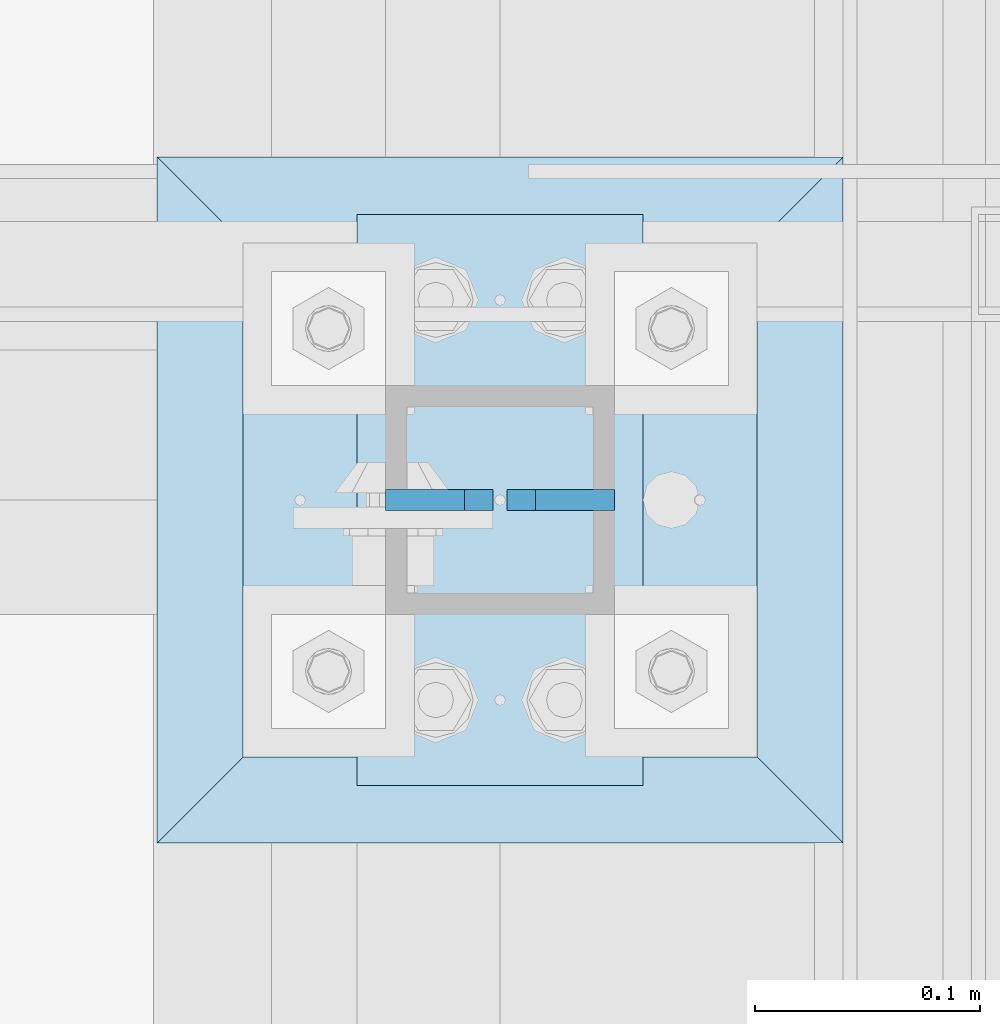
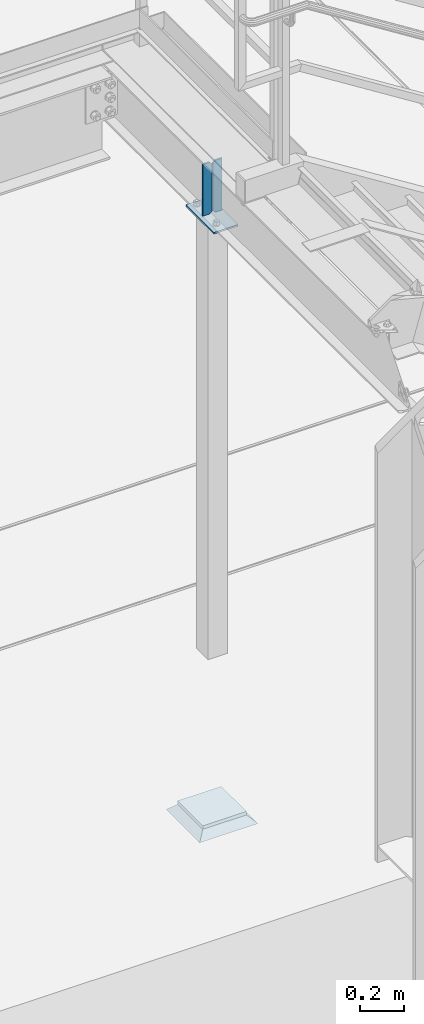
# One storey, part 3154 of 3843: 5 plates, 3 elements without a shape of their own.
"""IFC2X3 building model written with IfcOpenShell, lengths in millimetres."""

from ifc_helpers import new_model, si_unit, frame, origin_with_axes, place, context, subcontext, project, spatial, faceted_brep, material, type_object, element, aggregate, save


model = new_model("IFC2X3")

# Units and contexts
model_context = context("Model", 3, precision=1e-05, world=origin_with_axes())
body_context = subcontext(model_context, "Body", "Model", "MODEL_VIEW")
ifc_project = project(units=[si_unit("LENGTHUNIT", "METRE", prefix="MILLI"), si_unit("AREAUNIT", "SQUARE_METRE"), si_unit("VOLUMEUNIT", "CUBIC_METRE"), si_unit("MASSUNIT", "GRAM", prefix="KILO"), si_unit("TIMEUNIT", "SECOND"), si_unit("PLANEANGLEUNIT", "RADIAN"), si_unit("SOLIDANGLEUNIT", "STERADIAN"), si_unit("THERMODYNAMICTEMPERATUREUNIT", "DEGREE_CELSIUS"), si_unit("LUMINOUSINTENSITYUNIT", "LUMEN")], contexts=[model_context])

# Site, building, storey
site_placement = place(None, origin_with_axes())
site = spatial("IfcSite", under=ifc_project, at=site_placement, CompositionType="ELEMENT")
building_placement = place(site_placement, origin_with_axes())
building = spatial("IfcBuilding", under=site, at=building_placement, Name="Undefined", CompositionType="ELEMENT")
storey_placement = place(building_placement, origin_with_axes())
storey = spatial("IfcBuildingStorey", under=building, at=storey_placement, Name="Undefined", CompositionType="ELEMENT", Elevation=0.0)

# Assembly, plates
assembly_1_placement = place(storey_placement, origin_with_axes())
assembly_1 = element("IfcElementAssembly", 1, at=assembly_1_placement, inside=storey, Name="BEAM", AssemblyPlace="NOTDEFINED", PredefinedType="RIGID_FRAME")
ifc_material_1 = material(Name="STEEL/A572-50")
plate_type_1 = type_object("IfcPlateType", PredefinedType="NOTDEFINED")
plate_1_placement = place(assembly_1_placement, frame((55981.6, 27597.1, 33186.6874999995), z_axis=(0.0, 0.0, -1.0), x_axis=(-1.0, 0.0, 0.0)))
plate_1 = element("IfcPlate", 2, at=plate_1_placement, type_object=plate_type_1, material=ifc_material_1, Name="PLATE", context=body_context, shape_type="Brep", body=[
    faceted_brep([(0.0, -4.76249999999709, 0.0), (0.0, -4.7624999997206, 285.749999997672), (0.0, 4.7625000002663, 285.749999997664), (0.0, 4.76249999999709, 0.0), (34.9250001907349, -4.7624999997206, 285.749999997672), (34.9250001907349, 4.7625000002663, 285.749999997664), (47.625, -4.76249999972788, 273.050000188428), (47.625, 4.76250000025902, 273.050000188421), (47.625, -4.76249999998981, 12.6999998092579), (47.625, 4.76249999999709, 12.6999998092506), (34.9250001907349, -4.76249999999709, 1.45519152283669e-11), (34.9250001907349, 4.76249999998254, 0.0)], [[[0, 1, 2, 3]], [[1, 4, 5, 2]], [[4, 6, 7, 5]], [[6, 8, 9, 7]], [[8, 10, 11, 9]], [[10, 0, 3, 11]], [[5, 7, 9, 11, 3, 2]], [[10, 8, 6, 4, 1, 0]]]),
])
plate_2_placement = place(assembly_1_placement, frame((55880.0, 27597.1, 33186.6874999995), z_axis=(0.0, 0.0, -1.0), x_axis=(1.0, 0.0, 0.0)))
plate_2 = element("IfcPlate", 3, at=plate_2_placement, type_object=plate_type_1, material=ifc_material_1, Name="PLATE", context=body_context, shape_type="Brep", body=[
    faceted_brep([(0.0, -4.76249999999709, 0.0), (0.0, -4.7624999997206, 285.749999997672), (0.0, 4.7625000002663, 285.749999997664), (0.0, 4.76249999999709, 0.0), (34.9250001907349, -4.7624999997206, 285.749999997672), (34.9250001907349, 4.7625000002663, 285.749999997664), (47.625, -4.76249999972788, 273.050000188428), (47.625, 4.76250000025902, 273.050000188421), (47.625, -4.76249999998981, 12.6999998092579), (47.625, 4.76249999999709, 12.6999998092506), (34.9250001907349, -4.76249999999709, 1.45519152283669e-11), (34.9250001907349, 4.76249999998254, 0.0)], [[[0, 1, 2, 3]], [[1, 4, 5, 2]], [[4, 6, 7, 5]], [[6, 8, 9, 7]], [[8, 10, 11, 9]], [[10, 0, 3, 11]], [[5, 7, 9, 11, 3, 2]], [[10, 8, 6, 4, 1, 0]]]),
])
aggregate(assembly_1, [plate_1, plate_2])

assembly_2_placement = place(storey_placement, origin_with_axes())
assembly_2 = element("IfcElementAssembly", 4, at=assembly_2_placement, inside=storey, Name="COLUMN", AssemblyPlace="NOTDEFINED", PredefinedType="RIGID_FRAME")
plate_type_2 = type_object("IfcPlateType", PredefinedType="NOTDEFINED")
plate_3_placement = place(assembly_2_placement, frame((55816.5, 27482.8, 29613.225), z_axis=(0.0, 1.0, 0.0), x_axis=(1.0, 0.0, 0.0)))
plate_3 = element("IfcPlate", 5, at=plate_3_placement, type_object=plate_type_2, material=ifc_material_1, Name="PLATE", context=body_context, shape_type="Brep", body=[
    faceted_brep([(0.0, -9.52500000000146, 0.0), (0.0, -9.52500000000146, 228.600006103516), (0.0, 9.52500000000146, 228.600006103516), (0.0, 9.52500000000146, 0.0), (228.600006103516, -9.52500000000146, 228.600006103516), (228.600006103516, 9.52500000000146, 228.600006103516), (228.599999999999, -9.52500000000146, 0.0), (228.599999999999, 9.52500000000146, 0.0)], [[[0, 1, 2, 3]], [[1, 4, 5, 2]], [[4, 6, 7, 5]], [[6, 0, 3, 7]], [[5, 7, 3, 2]], [[6, 4, 1, 0]]]),
])
plate_type_3 = type_object("IfcPlateType", PredefinedType="NOTDEFINED")
plate_4_placement = place(assembly_2_placement, frame((55867.3, 27724.1, 32885.0624999995), z_axis=(0.0, -1.0, 0.0), x_axis=(1.0, 0.0, 0.0)))
plate_4 = element("IfcPlate", 6, at=plate_4_placement, type_object=plate_type_3, material=ifc_material_1, Name="PLATE", context=body_context, shape_type="Brep", body=[
    faceted_brep([(0.0, -4.76249999999709, 0.0), (0.0, -4.76249999999709, 254.0), (0.0, 4.76249999999709, 254.0), (0.0, 4.76249999999709, 0.0), (127.0, -4.76249999999709, 254.0), (127.0, 4.76249999999709, 254.0), (126.999992370605, -4.76249999999709, 0.0), (126.999992370605, 4.76249999999709, 0.0)], [[[0, 1, 2, 3]], [[1, 4, 5, 2]], [[4, 6, 7, 5]], [[6, 0, 3, 7]], [[5, 7, 3, 2]], [[6, 4, 1, 0]]]),
])
aggregate(assembly_2, [plate_4, plate_3])

# Assembly, plate
assembly_3_placement = place(storey_placement, origin_with_axes())
assembly_3 = element("IfcElementAssembly", 7, at=assembly_3_placement, inside=storey, Name="GROUT", AssemblyPlace="NOTDEFINED", PredefinedType="REINFORCEMENT_UNIT")
ifc_material_2 = material(Name="CONCRETE/Concrete_Undefined")
plate_type_4 = type_object("IfcPlateType", PredefinedType="NOTDEFINED")
plate_5_placement = place(assembly_3_placement, frame((55778.4, 27444.7, 29584.65), z_axis=(0.0, 1.0, 0.0), x_axis=(1.0, 0.0, 0.0)))
plate_5 = element("IfcPlate", 8, at=plate_5_placement, type_object=plate_type_4, material=ifc_material_2, Name="GROUT", context=body_context, shape_type="Brep", body=[
    faceted_brep([(38.0999999997875, -19.0499999997883, 266.699999999328), (0.0, 19.0499999999993, 304.799987792969), (0.0, 19.0500000000029, 0.0), (38.1000000006916, -19.0499999999811, 38.1000000006607), (266.700000000201, -19.0499999998174, 38.1000000006752), (304.799987792969, 19.0499999999993, 0.0), (304.799987792969, 19.0499999999993, 304.799987792969), (266.700000000201, -19.0499999999738, 266.699999999328)], [[[0, 1, 2, 3]], [[4, 5, 6, 7]], [[4, 7, 0, 3]], [[5, 4, 3, 2]], [[6, 5, 2, 1]], [[7, 6, 1, 0]]]),
])
aggregate(assembly_3, [plate_5])

save(model, "model.ifc")
